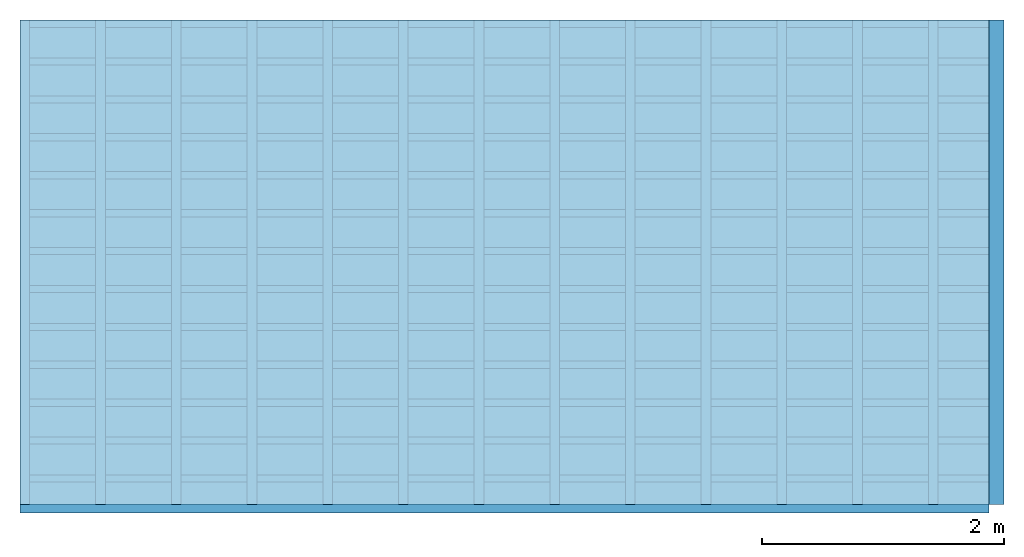
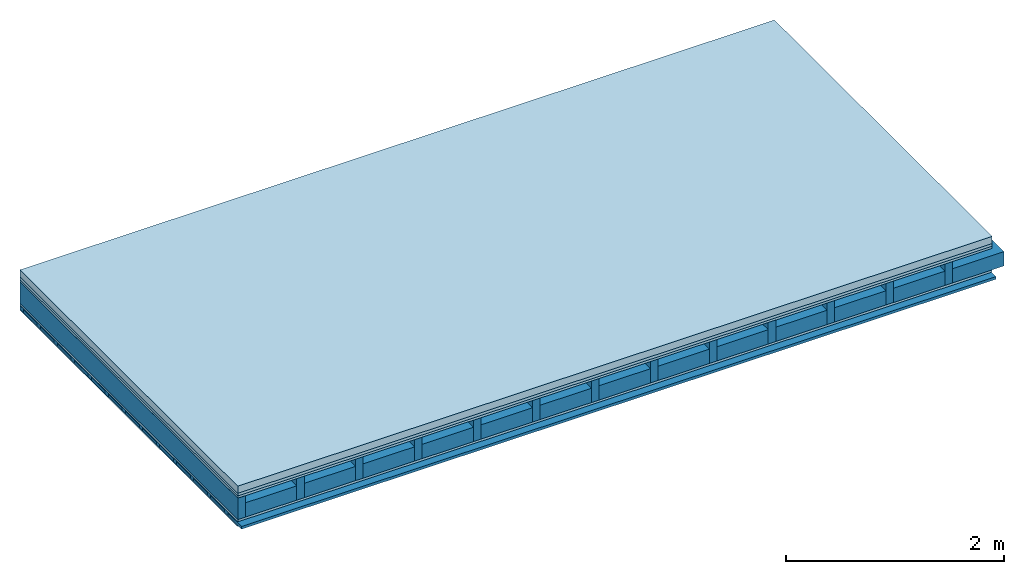
# One storey: 5 plates, 4 members, 1 element without a shape of its own.
"""IFC4 building model written with IfcOpenShell, lengths in metres."""

from ifc_helpers import new_model, si_unit, derived_unit, direction, frame, frame_2d, origin, origin_with_axes, place, context, project, spatial, rectangle, extrude, material, layer, layer_set, type_object, element, aggregate, save


model = new_model("IFC4")

# Units and contexts
plan_context = context("Plan", 3, precision=1e-05, world=origin(), true_north=direction((0.0, 1.0)))
model_context = context("Model", 3, precision=1e-05, world=origin(), true_north=direction((0.0, 1.0)))
ifc_project = project(units=[si_unit("LENGTHUNIT", "METRE"), derived_unit("SOUNDPRESSUREUNIT", [(si_unit("PRESSUREUNIT", "PASCAL", prefix="MICRO"), 0)]), si_unit("ENERGYUNIT", "JOULE", prefix="MEGA"), si_unit("MASSUNIT", "GRAM", prefix="KILO"), derived_unit("THERMALTRANSMITTANCEUNIT", [(si_unit("POWERUNIT", "WATT"), 1), (si_unit("AREAUNIT", "SQUARE_METRE"), -1), (si_unit("THERMODYNAMICTEMPERATUREUNIT", "KELVIN"), -1)]), derived_unit("AREADENSITYUNIT", [(si_unit("MASSUNIT", "GRAM", prefix="KILO"), 1), (si_unit("AREAUNIT", "SQUARE_METRE"), -1)]), derived_unit("USERDEFINED", [(si_unit("ENERGYUNIT", "JOULE", prefix="MEGA"), 1), (si_unit("AREAUNIT", "SQUARE_METRE"), -1)])], contexts=[plan_context, model_context])

# Site, building, storey
site = spatial("IfcSite", under=ifc_project)
building_placement = place(None, origin())
building = spatial("IfcBuilding", under=site, at=building_placement)
storey_placement = place(building_placement, origin())
storey = spatial("IfcBuildingStorey", under=building, at=storey_placement)

# Slab, members, plates
ifc_material_1 = material(Name="Cement screed", Category="04.006")
ifc_layer_1 = layer(ifc_material_1, 0.08, Name="On-material")
ifc_material_2 = material()
ifc_layer_2 = layer(ifc_material_2, 0.03, Name="Impact sound insulation")
ifc_material_3 = material(Category="07.001")
ifc_layer_3 = layer(ifc_material_3, 0.025, Name="Sub-floor")
ifc_material_4 = material(Name="Rigid, of the art")
ifc_layer_4 = layer(ifc_material_4, 0.0, Name="Bond")
ifc_layer_5 = layer(None, 0.24, Name="Supporting structure")
ifc_layer_6 = layer(ifc_material_4, 0.0, Name="Bond")
ifc_layer_7 = layer(ifc_material_3, 0.025, Name="Lower layer 1")
ifc_layer_8 = layer(None, 0.04, Name="Battens / profiles")
ifc_material_5 = material(Category="03.007")
ifc_layer_9 = layer(ifc_material_5, 0.015, Name="Ceiling covering 1st layer")
ifc_material_6 = material(Name="Glued joints")
ifc_layer_10 = layer(ifc_material_6, 0.0, Name="Surface / treatment")
ifc_layer_set = layer_set([ifc_layer_1, ifc_layer_2, ifc_layer_3, ifc_layer_4, ifc_layer_5, ifc_layer_6, ifc_layer_7, ifc_layer_8, ifc_layer_9, ifc_layer_10])
slab_type = type_object("IfcSlabType", Name="A0708", PredefinedType="NOTDEFINED", material=ifc_layer_set)
slab_placement = place(None, frame((0.0, 0.0, 0.0), z_axis=(0.0, 0.0, -1.0), x_axis=(1.0, 0.0, 0.0)))
slab = element("IfcSlab", 1, at=slab_placement, inside=storey, type_object=slab_type, material=ifc_layer_set, Name="Slab #1")
ifc_material_7 = material()
member_1_placement = place(slab_placement, origin())
member_1 = element("IfcMember", 2, at=member_1_placement, material=ifc_material_7, Name="Supporting structure", context=plan_context, shape_type="SweptSolid", body=[
    extrude(rectangle(XDim=0.08, YDim=0.24, at=frame_2d((0.04, 0.12), x_axis=(1.0, 0.0))), frame((0.0, 4.0, 0.135), z_axis=(0.0, -1.0, 0.0), x_axis=(1.0, 0.0, 0.0)), (0.0, 0.0, 1.0), 4.0),
    extrude(rectangle(XDim=0.08, YDim=0.24, at=frame_2d((0.04, 0.12), x_axis=(1.0, 0.0))), frame((0.625, 4.0, 0.135), z_axis=(0.0, -1.0, 0.0), x_axis=(1.0, 0.0, 0.0)), (0.0, 0.0, 1.0), 4.0),
    extrude(rectangle(XDim=0.08, YDim=0.24, at=frame_2d((0.04, 0.12), x_axis=(1.0, 0.0))), frame((1.25, 4.0, 0.135), z_axis=(0.0, -1.0, 0.0), x_axis=(1.0, 0.0, 0.0)), (0.0, 0.0, 1.0), 4.0),
    extrude(rectangle(XDim=0.08, YDim=0.24, at=frame_2d((0.04, 0.12), x_axis=(1.0, 0.0))), frame((1.875, 4.0, 0.135), z_axis=(0.0, -1.0, 0.0), x_axis=(1.0, 0.0, 0.0)), (0.0, 0.0, 1.0), 4.0),
    extrude(rectangle(XDim=0.08, YDim=0.24, at=frame_2d((0.04, 0.12), x_axis=(1.0, 0.0))), frame((2.5, 4.0, 0.135), z_axis=(0.0, -1.0, 0.0), x_axis=(1.0, 0.0, 0.0)), (0.0, 0.0, 1.0), 4.0),
    extrude(rectangle(XDim=0.08, YDim=0.24, at=frame_2d((0.04, 0.12), x_axis=(1.0, 0.0))), frame((3.125, 4.0, 0.135), z_axis=(0.0, -1.0, 0.0), x_axis=(1.0, 0.0, 0.0)), (0.0, 0.0, 1.0), 4.0),
    extrude(rectangle(XDim=0.08, YDim=0.24, at=frame_2d((0.04, 0.12), x_axis=(1.0, 0.0))), frame((3.75, 4.0, 0.135), z_axis=(0.0, -1.0, 0.0), x_axis=(1.0, 0.0, 0.0)), (0.0, 0.0, 1.0), 4.0),
    extrude(rectangle(XDim=0.08, YDim=0.24, at=frame_2d((0.04, 0.12), x_axis=(1.0, 0.0))), frame((4.375, 4.0, 0.135), z_axis=(0.0, -1.0, 0.0), x_axis=(1.0, 0.0, 0.0)), (0.0, 0.0, 1.0), 4.0),
    extrude(rectangle(XDim=0.08, YDim=0.24, at=frame_2d((0.04, 0.12), x_axis=(1.0, 0.0))), frame((5.0, 4.0, 0.135), z_axis=(0.0, -1.0, 0.0), x_axis=(1.0, 0.0, 0.0)), (0.0, 0.0, 1.0), 4.0),
    extrude(rectangle(XDim=0.08, YDim=0.24, at=frame_2d((0.04, 0.12), x_axis=(1.0, 0.0))), frame((5.625, 4.0, 0.135), z_axis=(0.0, -1.0, 0.0), x_axis=(1.0, 0.0, 0.0)), (0.0, 0.0, 1.0), 4.0),
    extrude(rectangle(XDim=0.08, YDim=0.24, at=frame_2d((0.04, 0.12), x_axis=(1.0, 0.0))), frame((6.25, 4.0, 0.135), z_axis=(0.0, -1.0, 0.0), x_axis=(1.0, 0.0, 0.0)), (0.0, 0.0, 1.0), 4.0),
    extrude(rectangle(XDim=0.08, YDim=0.24, at=frame_2d((0.04, 0.12), x_axis=(1.0, 0.0))), frame((6.875, 4.0, 0.135), z_axis=(0.0, -1.0, 0.0), x_axis=(1.0, 0.0, 0.0)), (0.0, 0.0, 1.0), 4.0),
    extrude(rectangle(XDim=0.08, YDim=0.24, at=frame_2d((0.04, 0.12), x_axis=(1.0, 0.0))), frame((7.5, 4.0, 0.135), z_axis=(0.0, -1.0, 0.0), x_axis=(1.0, 0.0, 0.0)), (0.0, 0.0, 1.0), 4.0),
])
ifc_material_8 = material()
member_2_placement = place(slab_placement, origin())
member_2 = element("IfcMember", 3, at=member_2_placement, material=ifc_material_8, Name="in supporting structure", context=plan_context, shape_type="SweptSolid", body=[
    extrude(rectangle(XDim=0.545, YDim=0.16, at=frame_2d((0.2725, 0.08), x_axis=(1.0, 0.0))), frame((0.08, 4.0, 0.215), z_axis=(0.0, -1.0, 0.0), x_axis=(1.0, 0.0, 0.0)), (0.0, 0.0, 1.0), 4.0),
    extrude(rectangle(XDim=0.545, YDim=0.16, at=frame_2d((0.2725, 0.08), x_axis=(1.0, 0.0))), frame((0.705, 4.0, 0.215), z_axis=(0.0, -1.0, 0.0), x_axis=(1.0, 0.0, 0.0)), (0.0, 0.0, 1.0), 4.0),
    extrude(rectangle(XDim=0.545, YDim=0.16, at=frame_2d((0.2725, 0.08), x_axis=(1.0, 0.0))), frame((1.33, 4.0, 0.215), z_axis=(0.0, -1.0, 0.0), x_axis=(1.0, 0.0, 0.0)), (0.0, 0.0, 1.0), 4.0),
    extrude(rectangle(XDim=0.545, YDim=0.16, at=frame_2d((0.2725, 0.08), x_axis=(1.0, 0.0))), frame((1.955, 4.0, 0.215), z_axis=(0.0, -1.0, 0.0), x_axis=(1.0, 0.0, 0.0)), (0.0, 0.0, 1.0), 4.0),
    extrude(rectangle(XDim=0.545, YDim=0.16, at=frame_2d((0.2725, 0.08), x_axis=(1.0, 0.0))), frame((2.58, 4.0, 0.215), z_axis=(0.0, -1.0, 0.0), x_axis=(1.0, 0.0, 0.0)), (0.0, 0.0, 1.0), 4.0),
    extrude(rectangle(XDim=0.545, YDim=0.16, at=frame_2d((0.2725, 0.08), x_axis=(1.0, 0.0))), frame((3.205, 4.0, 0.215), z_axis=(0.0, -1.0, 0.0), x_axis=(1.0, 0.0, 0.0)), (0.0, 0.0, 1.0), 4.0),
    extrude(rectangle(XDim=0.545, YDim=0.16, at=frame_2d((0.2725, 0.08), x_axis=(1.0, 0.0))), frame((3.83, 4.0, 0.215), z_axis=(0.0, -1.0, 0.0), x_axis=(1.0, 0.0, 0.0)), (0.0, 0.0, 1.0), 4.0),
    extrude(rectangle(XDim=0.545, YDim=0.16, at=frame_2d((0.2725, 0.08), x_axis=(1.0, 0.0))), frame((4.455, 4.0, 0.215), z_axis=(0.0, -1.0, 0.0), x_axis=(1.0, 0.0, 0.0)), (0.0, 0.0, 1.0), 4.0),
    extrude(rectangle(XDim=0.545, YDim=0.16, at=frame_2d((0.2725, 0.08), x_axis=(1.0, 0.0))), frame((5.08, 4.0, 0.215), z_axis=(0.0, -1.0, 0.0), x_axis=(1.0, 0.0, 0.0)), (0.0, 0.0, 1.0), 4.0),
    extrude(rectangle(XDim=0.545, YDim=0.16, at=frame_2d((0.2725, 0.08), x_axis=(1.0, 0.0))), frame((5.705, 4.0, 0.215), z_axis=(0.0, -1.0, 0.0), x_axis=(1.0, 0.0, 0.0)), (0.0, 0.0, 1.0), 4.0),
    extrude(rectangle(XDim=0.545, YDim=0.16, at=frame_2d((0.2725, 0.08), x_axis=(1.0, 0.0))), frame((6.33, 4.0, 0.215), z_axis=(0.0, -1.0, 0.0), x_axis=(1.0, 0.0, 0.0)), (0.0, 0.0, 1.0), 4.0),
    extrude(rectangle(XDim=0.545, YDim=0.16, at=frame_2d((0.2725, 0.08), x_axis=(1.0, 0.0))), frame((6.955, 4.0, 0.215), z_axis=(0.0, -1.0, 0.0), x_axis=(1.0, 0.0, 0.0)), (0.0, 0.0, 1.0), 4.0),
    extrude(rectangle(XDim=0.545, YDim=0.16, at=frame_2d((0.2725, 0.08), x_axis=(1.0, 0.0))), frame((7.58, 4.0, 0.215), z_axis=(0.0, -1.0, 0.0), x_axis=(1.0, 0.0, 0.0)), (0.0, 0.0, 1.0), 4.0),
])
ifc_material_9 = material()
member_3_placement = place(slab_placement, origin())
member_3 = element("IfcMember", 4, at=member_3_placement, material=ifc_material_9, Name="Battens / profiles", context=plan_context, shape_type="SweptSolid", body=[
    extrude(rectangle(XDim=0.06, YDim=0.04, at=frame_2d((0.03, 0.02), x_axis=(1.0, 0.0))), frame((0.0, 0.0, 0.4), z_axis=(1.0, 0.0, 0.0), x_axis=(0.0, 1.0, 0.0)), (0.0, 0.0, 1.0), 8.0),
    extrude(rectangle(XDim=0.06, YDim=0.04, at=frame_2d((0.03, 0.02), x_axis=(1.0, 0.0))), frame((0.0, 0.313, 0.4), z_axis=(1.0, 0.0, 0.0), x_axis=(0.0, 1.0, 0.0)), (0.0, 0.0, 1.0), 8.0),
    extrude(rectangle(XDim=0.06, YDim=0.04, at=frame_2d((0.03, 0.02), x_axis=(1.0, 0.0))), frame((0.0, 0.626, 0.4), z_axis=(1.0, 0.0, 0.0), x_axis=(0.0, 1.0, 0.0)), (0.0, 0.0, 1.0), 8.0),
    extrude(rectangle(XDim=0.06, YDim=0.04, at=frame_2d((0.03, 0.02), x_axis=(1.0, 0.0))), frame((0.0, 0.939, 0.4), z_axis=(1.0, 0.0, 0.0), x_axis=(0.0, 1.0, 0.0)), (0.0, 0.0, 1.0), 8.0),
    extrude(rectangle(XDim=0.06, YDim=0.04, at=frame_2d((0.03, 0.02), x_axis=(1.0, 0.0))), frame((0.0, 1.252, 0.4), z_axis=(1.0, 0.0, 0.0), x_axis=(0.0, 1.0, 0.0)), (0.0, 0.0, 1.0), 8.0),
    extrude(rectangle(XDim=0.06, YDim=0.04, at=frame_2d((0.03, 0.02), x_axis=(1.0, 0.0))), frame((0.0, 1.565, 0.4), z_axis=(1.0, 0.0, 0.0), x_axis=(0.0, 1.0, 0.0)), (0.0, 0.0, 1.0), 8.0),
    extrude(rectangle(XDim=0.06, YDim=0.04, at=frame_2d((0.03, 0.02), x_axis=(1.0, 0.0))), frame((0.0, 1.878, 0.4), z_axis=(1.0, 0.0, 0.0), x_axis=(0.0, 1.0, 0.0)), (0.0, 0.0, 1.0), 8.0),
    extrude(rectangle(XDim=0.06, YDim=0.04, at=frame_2d((0.03, 0.02), x_axis=(1.0, 0.0))), frame((0.0, 2.191, 0.4), z_axis=(1.0, 0.0, 0.0), x_axis=(0.0, 1.0, 0.0)), (0.0, 0.0, 1.0), 8.0),
    extrude(rectangle(XDim=0.06, YDim=0.04, at=frame_2d((0.03, 0.02), x_axis=(1.0, 0.0))), frame((0.0, 2.504, 0.4), z_axis=(1.0, 0.0, 0.0), x_axis=(0.0, 1.0, 0.0)), (0.0, 0.0, 1.0), 8.0),
    extrude(rectangle(XDim=0.06, YDim=0.04, at=frame_2d((0.03, 0.02), x_axis=(1.0, 0.0))), frame((0.0, 2.817, 0.4), z_axis=(1.0, 0.0, 0.0), x_axis=(0.0, 1.0, 0.0)), (0.0, 0.0, 1.0), 8.0),
    extrude(rectangle(XDim=0.06, YDim=0.04, at=frame_2d((0.03, 0.02), x_axis=(1.0, 0.0))), frame((0.0, 3.13, 0.4), z_axis=(1.0, 0.0, 0.0), x_axis=(0.0, 1.0, 0.0)), (0.0, 0.0, 1.0), 8.0),
    extrude(rectangle(XDim=0.06, YDim=0.04, at=frame_2d((0.03, 0.02), x_axis=(1.0, 0.0))), frame((0.0, 3.443, 0.4), z_axis=(1.0, 0.0, 0.0), x_axis=(0.0, 1.0, 0.0)), (0.0, 0.0, 1.0), 8.0),
    extrude(rectangle(XDim=0.06, YDim=0.04, at=frame_2d((0.03, 0.02), x_axis=(1.0, 0.0))), frame((0.0, 3.756, 0.4), z_axis=(1.0, 0.0, 0.0), x_axis=(0.0, 1.0, 0.0)), (0.0, 0.0, 1.0), 8.0),
])
ifc_material_10 = material()
member_4_placement = place(slab_placement, origin())
member_4 = element("IfcMember", 5, at=member_4_placement, material=ifc_material_10, Name="Cavity", context=plan_context, shape_type="SweptSolid", body=[
    extrude(rectangle(XDim=0.253, YDim=0.03, at=frame_2d((0.1265, 0.015), x_axis=(1.0, 0.0))), frame((0.0, 0.06, 0.41), z_axis=(1.0, 0.0, 0.0), x_axis=(0.0, 1.0, 0.0)), (0.0, 0.0, 1.0), 8.0),
    extrude(rectangle(XDim=0.253, YDim=0.03, at=frame_2d((0.1265, 0.015), x_axis=(1.0, 0.0))), frame((0.0, 0.373, 0.41), z_axis=(1.0, 0.0, 0.0), x_axis=(0.0, 1.0, 0.0)), (0.0, 0.0, 1.0), 8.0),
    extrude(rectangle(XDim=0.253, YDim=0.03, at=frame_2d((0.1265, 0.015), x_axis=(1.0, 0.0))), frame((0.0, 0.686, 0.41), z_axis=(1.0, 0.0, 0.0), x_axis=(0.0, 1.0, 0.0)), (0.0, 0.0, 1.0), 8.0),
    extrude(rectangle(XDim=0.253, YDim=0.03, at=frame_2d((0.1265, 0.015), x_axis=(1.0, 0.0))), frame((0.0, 0.999, 0.41), z_axis=(1.0, 0.0, 0.0), x_axis=(0.0, 1.0, 0.0)), (0.0, 0.0, 1.0), 8.0),
    extrude(rectangle(XDim=0.253, YDim=0.03, at=frame_2d((0.1265, 0.015), x_axis=(1.0, 0.0))), frame((0.0, 1.312, 0.41), z_axis=(1.0, 0.0, 0.0), x_axis=(0.0, 1.0, 0.0)), (0.0, 0.0, 1.0), 8.0),
    extrude(rectangle(XDim=0.253, YDim=0.03, at=frame_2d((0.1265, 0.015), x_axis=(1.0, 0.0))), frame((0.0, 1.625, 0.41), z_axis=(1.0, 0.0, 0.0), x_axis=(0.0, 1.0, 0.0)), (0.0, 0.0, 1.0), 8.0),
    extrude(rectangle(XDim=0.253, YDim=0.03, at=frame_2d((0.1265, 0.015), x_axis=(1.0, 0.0))), frame((0.0, 1.938, 0.41), z_axis=(1.0, 0.0, 0.0), x_axis=(0.0, 1.0, 0.0)), (0.0, 0.0, 1.0), 8.0),
    extrude(rectangle(XDim=0.253, YDim=0.03, at=frame_2d((0.1265, 0.015), x_axis=(1.0, 0.0))), frame((0.0, 2.251, 0.41), z_axis=(1.0, 0.0, 0.0), x_axis=(0.0, 1.0, 0.0)), (0.0, 0.0, 1.0), 8.0),
    extrude(rectangle(XDim=0.253, YDim=0.03, at=frame_2d((0.1265, 0.015), x_axis=(1.0, 0.0))), frame((0.0, 2.564, 0.41), z_axis=(1.0, 0.0, 0.0), x_axis=(0.0, 1.0, 0.0)), (0.0, 0.0, 1.0), 8.0),
    extrude(rectangle(XDim=0.253, YDim=0.03, at=frame_2d((0.1265, 0.015), x_axis=(1.0, 0.0))), frame((0.0, 2.877, 0.41), z_axis=(1.0, 0.0, 0.0), x_axis=(0.0, 1.0, 0.0)), (0.0, 0.0, 1.0), 8.0),
    extrude(rectangle(XDim=0.253, YDim=0.03, at=frame_2d((0.1265, 0.015), x_axis=(1.0, 0.0))), frame((0.0, 3.19, 0.41), z_axis=(1.0, 0.0, 0.0), x_axis=(0.0, 1.0, 0.0)), (0.0, 0.0, 1.0), 8.0),
    extrude(rectangle(XDim=0.253, YDim=0.03, at=frame_2d((0.1265, 0.015), x_axis=(1.0, 0.0))), frame((0.0, 3.503, 0.41), z_axis=(1.0, 0.0, 0.0), x_axis=(0.0, 1.0, 0.0)), (0.0, 0.0, 1.0), 8.0),
    extrude(rectangle(XDim=0.253, YDim=0.03, at=frame_2d((0.1265, 0.015), x_axis=(1.0, 0.0))), frame((0.0, 3.816, 0.41), z_axis=(1.0, 0.0, 0.0), x_axis=(0.0, 1.0, 0.0)), (0.0, 0.0, 1.0), 8.0),
])
plate_1_placement = place(slab_placement, origin())
plate_1 = element("IfcPlate", 6, at=plate_1_placement, material=ifc_material_1, Name="On-material", context=plan_context, shape_type="SweptSolid", body=[
    extrude(rectangle(XDim=8.0, YDim=4.0, at=frame_2d((4.0, 2.0), x_axis=(1.0, 0.0))), origin_with_axes(), (0.0, 0.0, 1.0), 0.08),
])
plate_2_placement = place(slab_placement, origin())
plate_2 = element("IfcPlate", 7, at=plate_2_placement, material=ifc_material_2, Name="Impact sound insulation", context=plan_context, shape_type="SweptSolid", body=[
    extrude(rectangle(XDim=8.0, YDim=4.0, at=frame_2d((4.0, 2.0), x_axis=(1.0, 0.0))), frame((0.0, 0.0, 0.08), z_axis=(0.0, 0.0, 1.0), x_axis=(1.0, 0.0, 0.0)), (0.0, 0.0, 1.0), 0.03),
])
plate_3_placement = place(slab_placement, origin())
plate_3 = element("IfcPlate", 8, at=plate_3_placement, material=ifc_material_3, Name="Sub-floor", context=plan_context, shape_type="SweptSolid", body=[
    extrude(rectangle(XDim=8.0, YDim=4.0, at=frame_2d((4.0, 2.0), x_axis=(1.0, 0.0))), frame((0.0, 0.0, 0.11), z_axis=(0.0, 0.0, 1.0), x_axis=(1.0, 0.0, 0.0)), (0.0, 0.0, 1.0), 0.025),
])
plate_4_placement = place(slab_placement, origin())
plate_4 = element("IfcPlate", 9, at=plate_4_placement, material=ifc_material_3, Name="Lower layer 1", context=plan_context, shape_type="SweptSolid", body=[
    extrude(rectangle(XDim=8.0, YDim=4.0, at=frame_2d((4.0, 2.0), x_axis=(1.0, 0.0))), frame((0.0, 0.0, 0.375), z_axis=(0.0, 0.0, 1.0), x_axis=(1.0, 0.0, 0.0)), (0.0, 0.0, 1.0), 0.025),
])
plate_5_placement = place(slab_placement, origin())
plate_5 = element("IfcPlate", 10, at=plate_5_placement, material=ifc_material_5, Name="Ceiling covering 1st layer", context=plan_context, shape_type="SweptSolid", body=[
    extrude(rectangle(XDim=8.0, YDim=4.0, at=frame_2d((4.0, 2.0), x_axis=(1.0, 0.0))), frame((0.0, 0.0, 0.44), z_axis=(0.0, 0.0, 1.0), x_axis=(1.0, 0.0, 0.0)), (0.0, 0.0, 1.0), 0.015),
])
aggregate(slab, [plate_1, plate_2, plate_3, member_1, member_2, plate_4, member_3, member_4, plate_5])

save(model, "model.ifc")
